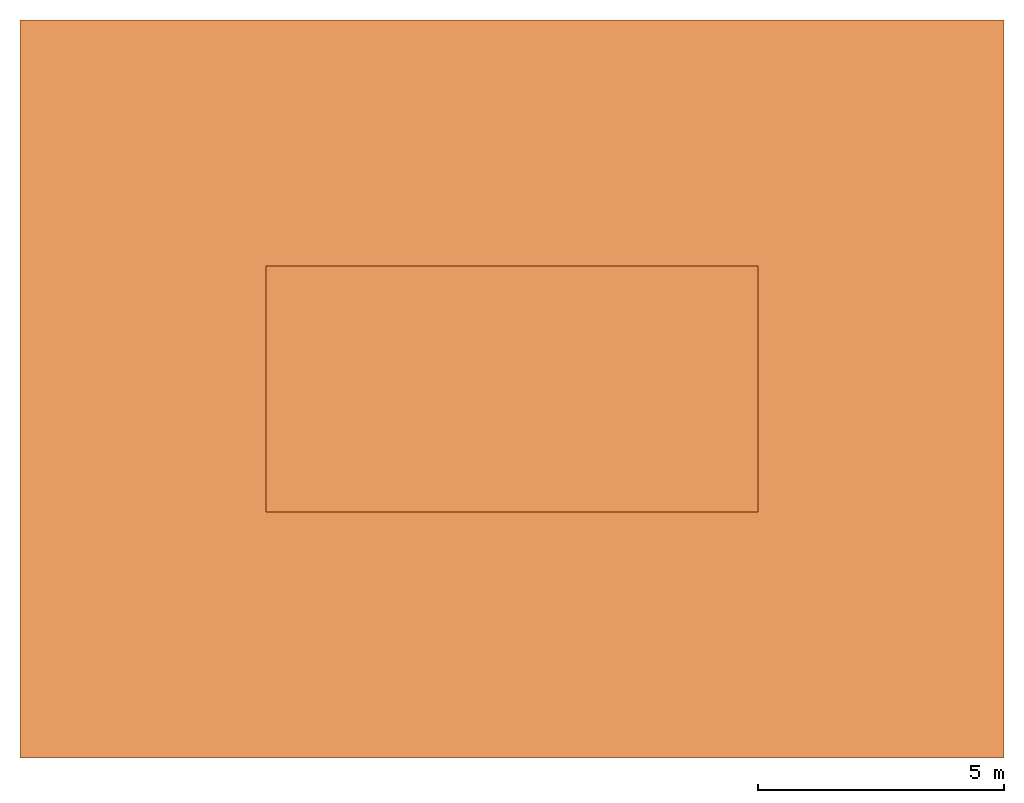
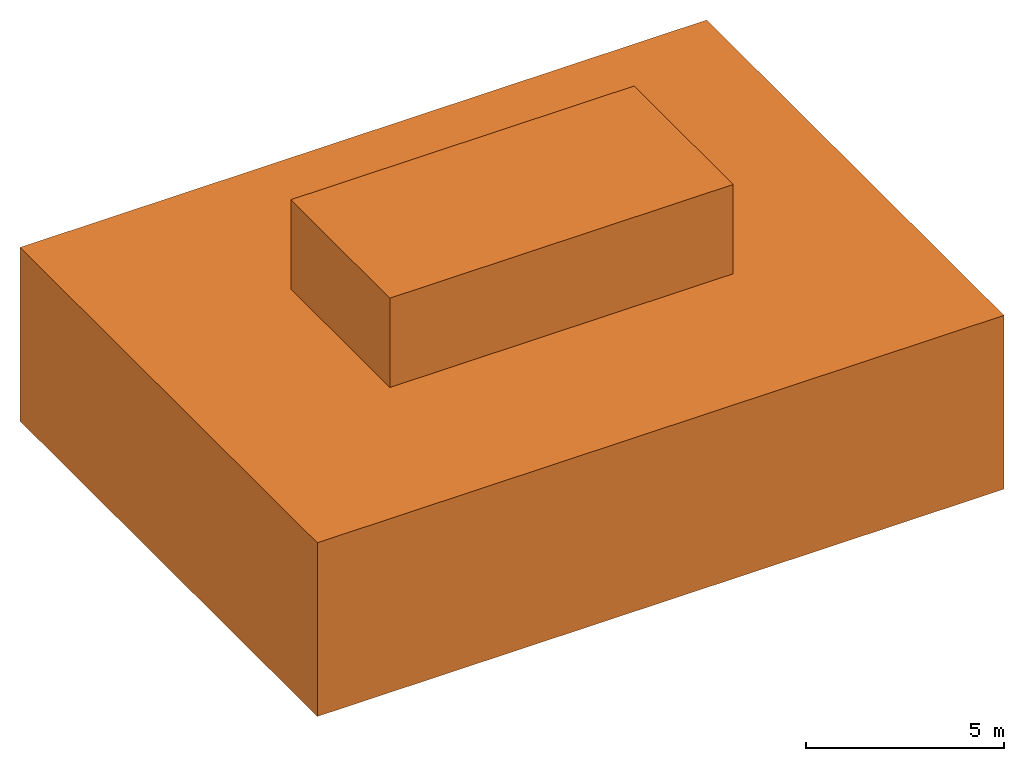
# One storey: 1 proxy.
"""IFC2X3 building model written with IfcOpenShell, lengths in millimetres."""

from ifc_helpers import new_model, si_unit, direction, frame, origin, origin_with_axes, place, context, project, spatial, faceted_brep, material, element, save


model = new_model("IFC2X3")

# Units and contexts
model_context = context("Model", 3, world=origin(), true_north=direction((0.0, 1.0, 0.0)))
ifc_project = project(units=[si_unit("LENGTHUNIT", "METRE", prefix="MILLI"), si_unit("AREAUNIT", "SQUARE_METRE"), si_unit("VOLUMEUNIT", "CUBIC_METRE")], contexts=[model_context])

# Site, building, storey
site_placement = place(None, origin_with_axes())
site = spatial("IfcSite", under=ifc_project, at=site_placement, CompositionType="ELEMENT")
building_placement = place(site_placement, origin_with_axes())
building = spatial("IfcBuilding", under=site, at=building_placement, Name="Default Building", CompositionType="ELEMENT")
storey_placement = place(building_placement, origin_with_axes())
storey = spatial("IfcBuildingStorey", under=building, at=storey_placement, Name="Default Building Storey", CompositionType="ELEMENT", Elevation=0.0)

# Proxy
ifc_material = material(Name="Default")
proxy_placement = place(storey_placement, frame((-5000.0, -5000.000000000001, -5000.0), z_axis=(0.0, 0.0, 1.0), x_axis=(1.0, 0.0, 0.0)))
element("IfcBuildingElementProxy", 1, at=proxy_placement, inside=storey, material=ifc_material, Name="Project", context=model_context, shape_type="Brep", body=[
    faceted_brep([(10099.999999999989, 5000.000000000001, 7749.999999999999), (10099.999999999989, 5000.000000000001, 5350.0), (12374.999999999987, 5000.000000000002, 5350.0), (12374.999999999987, 5000.000000000002, 7749.999999999999), (10149.99999999999, 5000.000000000001, 5400.0), (10149.99999999999, 5000.000000000001, 7699.999999999999), (12324.999999999987, 5000.000000000002, 7699.999999999999), (12324.999999999987, 5000.000000000002, 5400.0), (10099.999999999989, 5050.000000000001, 5350.0), (10099.999999999989, 5050.000000000001, 7749.999999999999), (12374.999999999987, 5050.000000000002, 7749.999999999999), (12374.999999999987, 5050.000000000002, 5350.0), (10149.99999999999, 5050.000000000001, 7699.999999999999), (10149.99999999999, 5050.000000000001, 5400.0), (12324.999999999987, 5050.000000000002, 5400.0), (12324.999999999987, 5050.000000000002, 7699.999999999999), (10149.99999999999, 5035.000000000001, 7699.999999999999), (10149.99999999999, 5010.000000000001, 7699.999999999999), (10149.99999999999, 5010.000000000001, 5400.0), (10149.99999999999, 5035.000000000001, 5400.0), (12324.999999999987, 5035.000000000002, 7699.999999999999), (12324.999999999987, 5010.000000000002, 7699.999999999999), (12324.999999999987, 5035.000000000002, 5400.0), (12324.999999999987, 5010.000000000002, 5400.0)], [[[0, 1, 2, 3], [4, 5, 6, 7]], [[8, 9, 10, 11], [12, 13, 14, 15]], [[1, 0, 9, 8]], [[2, 1, 8, 11]], [[3, 2, 11, 10]], [[0, 3, 10, 9]], [[16, 17, 18, 19]], [[20, 21, 17, 16]], [[22, 23, 21, 20]], [[19, 18, 23, 22]], [[19, 16, 20, 22]], [[13, 12, 16, 19]], [[12, 15, 20, 16]], [[15, 14, 22, 20]], [[14, 13, 19, 22]], [[17, 18, 23, 21]], [[5, 4, 18, 17]], [[4, 7, 23, 18]], [[7, 6, 21, 23]], [[6, 5, 17, 21]]]),
    faceted_brep([(7624.999999999998, 5000.000000000004, 7749.999999999999), (7624.999999999998, 5000.000000000004, 5350.0), (9899.999999999995, 5000.000000000002, 5350.0), (9899.999999999995, 5000.000000000002, 7749.999999999999), (7674.999999999998, 5000.000000000004, 5400.0), (7674.999999999998, 5000.000000000004, 7699.999999999999), (9849.999999999995, 5000.000000000002, 7699.999999999999), (9849.999999999995, 5000.000000000002, 5400.0), (7624.999999999998, 5050.000000000004, 5350.0), (7624.999999999998, 5050.000000000004, 7749.999999999999), (9899.999999999995, 5050.000000000002, 7749.999999999999), (9899.999999999995, 5050.000000000002, 5350.0), (7674.999999999998, 5050.000000000004, 7699.999999999999), (7674.999999999998, 5050.000000000004, 5400.0), (9849.999999999995, 5050.000000000002, 5400.0), (9849.999999999995, 5050.000000000002, 7699.999999999999), (9849.999999999995, 5035.000000000002, 5400.0), (9849.999999999995, 5010.000000000002, 5400.0), (9849.999999999995, 5010.000000000002, 7699.999999999999), (9849.999999999995, 5035.000000000002, 7699.999999999999), (7674.999999999998, 5010.000000000004, 7699.999999999999), (7674.999999999998, 5035.000000000004, 7699.999999999999), (7674.999999999998, 5010.000000000004, 5400.0), (7674.999999999998, 5035.000000000004, 5400.0)], [[[0, 1, 2, 3], [4, 5, 6, 7]], [[8, 9, 10, 11], [12, 13, 14, 15]], [[11, 10, 3, 2]], [[8, 11, 2, 1]], [[9, 8, 1, 0]], [[10, 9, 0, 3]], [[16, 17, 18, 19]], [[19, 18, 20, 21]], [[21, 20, 22, 23]], [[23, 22, 17, 16]], [[23, 21, 19, 16]], [[16, 19, 15, 14]], [[19, 21, 12, 15]], [[21, 23, 13, 12]], [[23, 16, 14, 13]], [[20, 22, 17, 18]], [[18, 17, 7, 6]], [[17, 22, 4, 7]], [[22, 20, 5, 4]], [[20, 18, 6, 5]]]),
    faceted_brep([(13650.0, 9999.999999999998, 5350.0), (13650.0, 10000.00000000001, 7749.999999999999), (14650.0, 10000.00000000001, 7749.999999999999), (14650.0, 9999.999999999998, 5350.0), (13650.0, 9950.00000000001, 7749.999999999999), (13650.0, 9949.999999999998, 5350.0), (14650.0, 9949.999999999998, 5350.0), (14650.0, 9950.00000000001, 7749.999999999999)], [[[0, 1, 2, 3]], [[4, 5, 6, 7]], [[1, 0, 5, 4]], [[2, 1, 4, 7]], [[3, 2, 7, 6]], [[0, 3, 6, 5]]]),
    faceted_brep([(5000.000000000001, 10000.000000000002, 5000.0), (14999.999999999998, 10000.000000000002, 5000.0), (14999.999999999998, 5000.000000000001, 5000.0), (5000.0, 5000.000000000001, 5000.0), (5000.0, 5000.000000000001, 8100.0), (5000.000000000001, 10000.000000000002, 8100.0), (14999.999999999998, 5000.000000000001, 8100.0), (14999.999999999998, 10000.000000000002, 8100.0)], [[[0, 1, 2, 3]], [[0, 3, 4, 5]], [[3, 2, 6, 4]], [[1, 0, 5, 7]], [[7, 5, 4, 6]], [[2, 1, 7, 6]]]),
    faceted_brep([(9900.000000000013, 8650.000000000002, 5350.0), (9900.000000000002, 8650.000000000002, 7749.999999999999), (9900.000000000002, 9650.000000000004, 7749.999999999999), (9900.000000000013, 9650.000000000004, 5350.0), (9950.000000000002, 8650.000000000002, 7749.999999999999), (9950.000000000013, 8650.000000000002, 5350.0), (9950.000000000013, 9650.000000000004, 5350.0), (9950.000000000002, 9650.000000000004, 7749.999999999999)], [[[0, 1, 2, 3]], [[4, 5, 6, 7]], [[1, 0, 5, 4]], [[2, 1, 4, 7]], [[3, 2, 7, 6]], [[0, 3, 6, 5]]]),
    faceted_brep([(5350.000000000001, 9650.000000000002, 7749.999999999999), (9900.0, 9650.000000000002, 7749.999999999999), (9900.0, 5350.0, 7749.999999999999), (5350.0, 5350.0, 7749.999999999999), (5350.0, 5350.0, 5350.0), (5350.000000000001, 9650.000000000002, 5350.0), (14650.0, 9650.000000000002, 5350.0), (14650.0, 5350.0, 5350.0), (14650.0, 5350.0, 7749.999999999999), (14650.0, 9650.000000000002, 7749.999999999999), (10100.000000000002, 9650.000000000002, 7749.999999999999), (10100.000000000002, 9650.000000000002, 5350.0), (9900.0, 5350.0, 5350.0), (9900.0, 9650.000000000002, 5350.0), (10100.0, 5350.0, 5350.0), (10100.0, 5350.0, 7749.999999999999)], [[[0, 1, 2, 3]], [[4, 5, 0, 3]], [[6, 7, 8, 9]], [[9, 10, 11, 6]], [[3, 2, 12, 4]], [[13, 12, 2, 1]], [[4, 12, 13, 5]], [[6, 11, 14, 7]], [[14, 11, 10, 15]], [[13, 1, 0, 5]], [[8, 15, 10, 9]], [[14, 15, 8, 7]]]),
    faceted_brep([(19999.999999999996, 0.0, 0.0), (19999.999999999996, 15000.000000000002, 0.0), (19999.999999999996, 15000.000000000002, 5350.0), (19999.999999999996, 0.0, 5350.0), (0.0, 0.0, 0.0), (0.0, 15000.000000000002, 0.0), (5000.000000000001, 5000.000000000001, 5350.0), (14999.999999999998, 5000.000000000001, 5350.0), (14999.999999999998, 5000.000000000001, 5000.0), (5000.000000000001, 5000.000000000001, 5000.0), (5000.000000000001, 10000.000000000002, 5350.0), (5000.000000000001, 10000.000000000002, 5000.0), (14999.999999999998, 10000.0, 5350.0), (14999.999999999998, 10000.0, 5000.0), (0.0, 0.0, 5350.0), (0.0, 15000.000000000002, 5350.0)], [[[0, 1, 2, 3]], [[0, 4, 5, 1]], [[6, 7, 8, 9]], [[10, 6, 9, 11]], [[7, 12, 13, 8]], [[12, 10, 11, 13]], [[4, 0, 3, 14]], [[1, 5, 15, 2]], [[14, 3, 2, 15], [12, 7, 6, 10]], [[5, 4, 14, 15]], [[8, 13, 11, 9]]]),
    faceted_brep([(10100.000000000002, 9650.000000000002, 6676.346926056653), (13649.999999999996, 9650.000000000002, 6676.346926056653), (13650.0, 9950.000000000004, 6676.346926056653), (13650.0, 10000.000000000002, 6676.346926056653), (5000.000000000001, 10000.000000000002, 6676.346926056653), (5000.0, 5000.000000000002, 6676.346926056653), (7624.999999999998, 5000.000000000001, 6676.346926056653), (7624.999999999998, 5050.000000000004, 6676.346926056653), (7625.000000000003, 5350.0, 6676.346926056653), (5350.0, 5350.0, 6676.346926056653), (5350.000000000001, 9650.000000000002, 6676.346926056653), (9900.0, 9650.000000000002, 6676.346926056653), (9950.000000000007, 9650.000000000004, 6676.346926056653), (5330.0, 5330.000000000001, 6676.346926056653), (7605.000000000003, 5330.000000000001, 6676.346926056653), (7605.0, 5070.000000000001, 6676.346926056653), (7604.999999999999, 5050.000000000005, 6676.346926056653), (7604.999999999999, 5020.0, 6676.346926056653), (5020.0, 5020.000000000002, 6676.346926056653), (5020.000000000001, 9980.0, 6676.346926056653), (13629.999999999998, 9980.0, 6676.346926056653), (13629.999999999998, 9950.000000000004, 6676.346926056653), (13629.999999999998, 9930.0, 6676.346926056653), (13629.999999999996, 9670.000000000002, 6676.346926056653), (10100.000000000002, 9670.000000000002, 6676.346926056653), (9950.000000000007, 9670.000000000002, 6676.346926056653), (9900.0, 9670.000000000002, 6676.346926056653), (5330.000000000001, 9670.000000000002, 6676.346926056653), (9900.0, 8650.000000000002, 6676.346926056653), (9900.0, 5350.0, 6676.346926056653), (9899.999999999995, 5050.000000000002, 6676.346926056653), (9899.999999999995, 5000.000000000001, 6676.346926056653), (10099.999999999989, 5000.000000000001, 6676.346926056653), (10099.999999999989, 5050.000000000001, 6676.346926056653), (10100.0, 5350.0, 6676.346926056653), (10100.000000000002, 8650.0, 6676.346926056653), (9950.000000000007, 8650.000000000002, 6676.346926056653), (9920.0, 5350.0, 6676.346926056653), (9920.0, 8630.0, 6676.346926056653), (9950.000000000007, 8630.0, 6676.346926056653), (10080.000000000002, 8630.0, 6676.346926056653), (10080.0, 5350.000000000001, 6676.346926056653), (10079.99999999999, 5070.000000000001, 6676.346926056653), (10079.99999999999, 5050.000000000002, 6676.346926056653), (10079.99999999999, 5020.0, 6676.346926056653), (9919.999999999995, 5020.0, 6676.346926056653), (9919.999999999996, 5050.000000000002, 6676.346926056653), (9919.999999999996, 5070.000000000001, 6676.346926056653), (12324.999999999987, 5010.000000000002, 6676.346926056653), (12324.999999999987, 5035.000000000002, 6676.346926056653), (10149.99999999999, 5035.000000000001, 6676.346926056653), (10149.99999999999, 5010.000000000001, 6676.346926056653), (12324.999999999987, 5000.000000000002, 6676.346926056653), (12374.999999999984, 5000.000000000001, 6676.346926056653), (12374.999999999987, 5050.000000000002, 6676.346926056653), (12324.999999999987, 5050.000000000002, 6676.346926056653), (14999.999999999996, 5000.000000000001, 6676.346926056653), (14999.999999999998, 10000.000000000002, 6676.346926056653), (14650.0, 10000.000000000002, 6676.346926056653), (14650.0, 9950.000000000004, 6676.346926056653), (14650.0, 9650.000000000002, 6676.346926056653), (14650.0, 5350.0, 6676.346926056653), (12374.999999999989, 5350.0, 6676.346926056653), (14980.0, 9980.0, 6676.346926056653), (14979.999999999998, 5020.0, 6676.346926056653), (12394.999999999985, 5020.0, 6676.346926056653), (12394.999999999987, 5050.000000000002, 6676.346926056653), (12394.999999999987, 5070.000000000001, 6676.346926056653), (12394.99999999999, 5330.000000000001, 6676.346926056653), (14669.999999999998, 5330.000000000001, 6676.346926056653), (14669.999999999998, 9930.0, 6676.346926056653), (14669.999999999998, 9950.000000000004, 6676.346926056653), (14669.999999999998, 9980.0, 6676.346926056653), (10149.99999999999, 5000.000000000001, 6676.346926056653), (10149.99999999999, 5050.000000000001, 6676.346926056653), (9849.999999999995, 5010.000000000003, 6676.346926056653), (9849.999999999995, 5035.000000000002, 6676.346926056653), (7674.999999999998, 5035.000000000004, 6676.346926056653), (7674.999999999998, 5010.000000000004, 6676.346926056653), (9849.999999999995, 5000.000000000002, 6676.346926056653), (9849.999999999995, 5050.000000000002, 6676.346926056653), (7674.999999999998, 5000.000000000004, 6676.346926056653), (7674.999999999998, 5050.000000000004, 6676.346926056653), (5070.000000000001, 9930.0, 6676.346926056653), (5070.0, 5070.000000000002, 6676.346926056653), (14930.0, 9930.0, 6676.346926056653), (14929.999999999998, 5070.000000000001, 6676.346926056653)], [[[0, 1, 2, 3, 4, 5, 6, 7, 8, 9, 10, 11, 12], [13, 14, 15, 16, 17, 18, 19, 20, 21, 22, 23, 24, 25, 26, 27]], [[28, 29, 30, 31, 32, 33, 34, 35, 36], [37, 38, 39, 40, 41, 42, 43, 44, 45, 46, 47]], [[48, 49, 50, 51]], [[49, 48, 52, 53, 54, 55]], [[56, 57, 58, 59, 60, 61, 62, 54, 53], [63, 64, 65, 66, 67, 68, 69, 70, 71, 72]], [[32, 73, 51, 50, 74, 33]], [[75, 76, 77, 78]], [[76, 75, 79, 31, 30, 80]], [[6, 81, 78, 77, 82, 7]], [[58, 3, 2, 59]], [[36, 12, 11, 28]], [[15, 14, 13, 27, 26, 25, 24, 23, 22, 83, 84]], [[71, 70, 85, 86, 67, 66, 65, 64, 63, 72]], [[85, 70, 69, 68, 67, 86]], [[83, 22, 21, 20, 19, 18, 17, 16, 15, 84]], [[43, 42, 47, 46, 45, 44]], [[37, 47, 42, 41, 40, 39, 38]]]),
])

save(model, "model.ifc")
